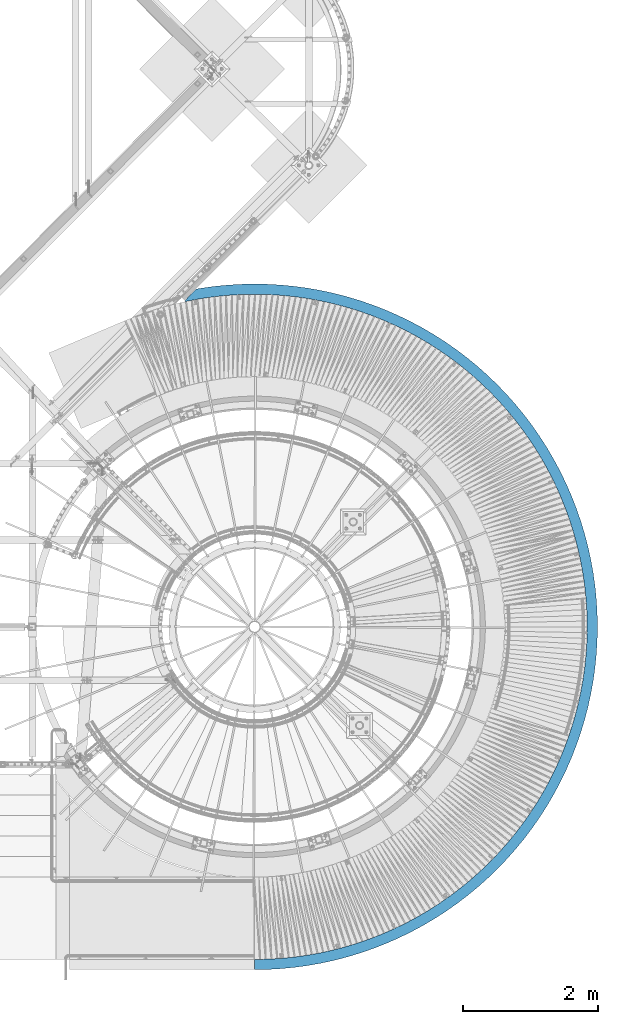
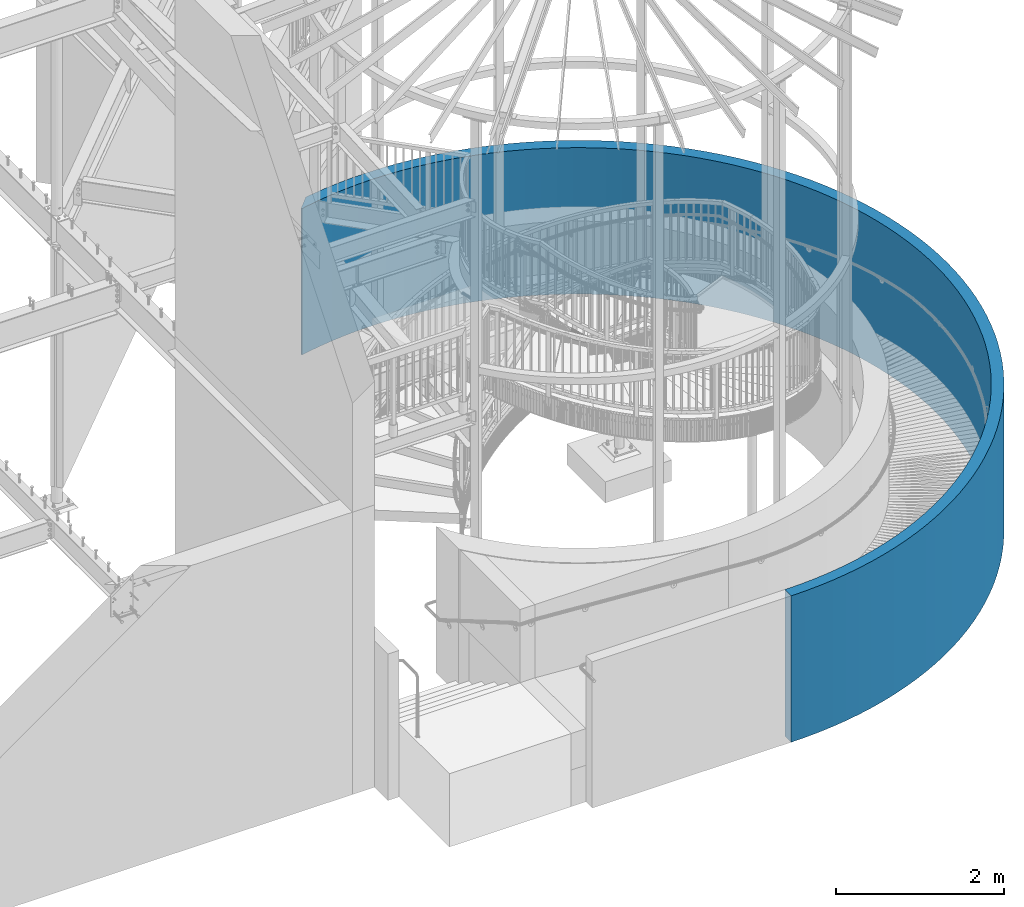
# One storey, part 362 of 975: 1 beam.
"""IFC2X3 building model written with IfcOpenShell, lengths in millimetres."""

from ifc_helpers import new_model, si_unit, frame, origin_with_axes, place, context, subcontext, project, spatial, faceted_brep, material, type_object, element, save


model = new_model("IFC2X3")

# Units and contexts
model_context = context("Model", 3, precision=1e-05, world=origin_with_axes())
body_context = subcontext(model_context, "Body", "Model", "MODEL_VIEW")
ifc_project = project(units=[si_unit("LENGTHUNIT", "METRE", prefix="MILLI"), si_unit("AREAUNIT", "SQUARE_METRE"), si_unit("VOLUMEUNIT", "CUBIC_METRE"), si_unit("MASSUNIT", "GRAM", prefix="KILO"), si_unit("TIMEUNIT", "SECOND"), si_unit("PLANEANGLEUNIT", "RADIAN"), si_unit("SOLIDANGLEUNIT", "STERADIAN"), si_unit("THERMODYNAMICTEMPERATUREUNIT", "DEGREE_CELSIUS"), si_unit("LUMINOUSINTENSITYUNIT", "LUMEN")], contexts=[model_context])

# Site, building, storey
site_placement = place(None, origin_with_axes())
site = spatial("IfcSite", under=ifc_project, at=site_placement, CompositionType="ELEMENT")
building_placement = place(site_placement, origin_with_axes())
building = spatial("IfcBuilding", under=site, at=building_placement, Name="Undefined", CompositionType="ELEMENT")
storey_placement = place(building_placement, origin_with_axes())
storey = spatial("IfcBuildingStorey", under=building, at=storey_placement, Name="Undefined", CompositionType="ELEMENT", Elevation=0.0)

# Beam
ifc_material = material(Name="STEEL/Zero_Density")
beam_type = type_object("IfcBeamType", PredefinedType="NOTDEFINED")
beam_placement = place(storey_placement, frame((34734.5000002246, 3403.60000026434, 2133.6), z_axis=(0.0, -1.0, 0.0), x_axis=(0.0, 0.0, -1.0)))
element("IfcBeam", 1, at=beam_placement, inside=storey, type_object=beam_type, material=ifc_material, Name="WALL", context=body_context, shape_type="Brep", body=[
    faceted_brep([(2133.6, 0.000133240799186751, 5079.99999999993), (0.0, 0.0, 5080.0), (0.0, 0.0, 4927.6), (2133.6, 0.0, 4927.6), (2133.6, -1031.57951941627, -4833.76233125407), (0.0, -1031.57951941627, -4833.76233125407), (0.0, -869.616967607908, -5004.07599048647), (2133.6, -869.616967607959, -5004.07599048646), (2133.6, -1029.59786975904, -4817.938464814), (0.0, -1029.59786975906, -4817.938464814), (0.0, 193.456668134386, 4923.80099897979), (2133.6, 193.456668134386, 4923.80099897979), (0.0, 386.615040108532, 4912.40985370336), (2133.6, 386.615040108532, 4912.40985370336), (0.0, 579.177279713243, 4893.4441284911), (2133.6, 579.177279713243, 4893.4441284911), (0.0, 770.846469932243, 4866.9330671166), (2133.6, 770.846469932243, 4866.9330671166), (0.0, 961.327070766674, 4832.91754771496), (2133.6, 961.327070766674, 4832.91754771496), (0.0, 1150.32537493636, 4791.45001975159), (2133.6, 1150.32537493636, 4791.45001975159), (0.0, 1337.54996075514, 4742.59442314899), (2133.6, 1337.54996075514, 4742.59442314899), (0.0, 1522.71214148199, 4686.426089696), (2133.6, 1522.71214148199, 4686.426089696), (0.0, 1705.52641045506, 4623.03162689163), (2133.6, 1705.52641045506, 4623.03162689163), (0.0, 1885.71088132222, 4552.50878440262), (2133.6, 1885.71088132222, 4552.50878440262), (0.0, 2062.98772268943, 4474.96630334047), (2133.6, 2062.98772268943, 4474.96630334047), (0.0, 2237.08358651659, 4390.5237485906), (2133.6, 2237.08358651659, 4390.5237485906), (0.0, 2407.7300296004, 4299.31132445191), (2133.6, 2407.7300296004, 4299.31132445191), (0.0, 2574.66392749431, 4201.46967387123), (2133.6, 2574.66392749431, 4201.46967387123), (0.0, 2737.6278802274, 4097.14966158202), (2133.6, 2737.6278802274, 4097.14966158202), (0.0, 2896.37060919639, 3986.51214148199), (2133.6, 2896.37060919639, 3986.51214148199), (0.0, 3050.64734461914, 3869.72770860796), (2133.6, 3050.64734461914, 3869.72770860796), (0.0, 3200.22020295182, 3746.97643609071), (2133.6, 3200.22020295182, 3746.97643609071), (0.0, 3344.85855368812, 3618.44759749528), (2133.6, 3344.85855368812, 3618.44759749528), (0.0, 3484.33937497484, 3484.33937497483), (2133.6, 3484.33937497484, 3484.33937497483), (0.0, 3618.44759749529, 3344.85855368812), (2133.6, 3618.44759749529, 3344.85855368812), (0.0, 3746.97643609071, 3200.22020295181), (2133.6, 3746.97643609071, 3200.22020295181), (0.0, 3869.72770860796, 3050.64734461914), (2133.6, 3869.72770860796, 3050.64734461914), (0.0, 3986.512141482, 2896.37060919639), (2133.6, 3986.512141482, 2896.37060919639), (0.0, 4097.14966158202, 2737.62788022739), (2133.6, 4097.14966158202, 2737.62788022739), (0.0, 4201.46967387122, 2574.66392749431), (2133.6, 4201.46967387122, 2574.66392749431), (0.0, 4299.31132445191, 2407.7300296004), (2133.6, 4299.31132445191, 2407.7300296004), (0.0, 4390.5237485906, 2237.08358651659), (2133.6, 4390.5237485906, 2237.08358651659), (0.0, 4474.96630334047, 2062.98772268943), (2133.6, 4474.96630334047, 2062.98772268943), (0.0, 4552.50878440262, 1885.71088132222), (2133.6, 4552.50878440262, 1885.71088132222), (0.0, 4623.03162689164, 1705.52641045505), (2133.6, 4623.03162689164, 1705.52641045505), (0.0, 4686.426089696, 1522.71214148199), (2133.6, 4686.426089696, 1522.71214148199), (0.0, 4742.59442314899, 1337.54996075514), (2133.6, 4742.59442314899, 1337.54996075514), (0.0, 4791.4500197516, 1150.32537493636), (2133.6, 4791.4500197516, 1150.32537493636), (0.0, 4832.91754771496, 961.327070766674), (2133.6, 4832.91754771496, 961.327070766674), (0.0, 4866.9330671166, 770.846469932241), (2133.6, 4866.9330671166, 770.846469932241), (0.0, 4893.44412849109, 579.177279713239), (2133.6, 4893.44412849109, 579.177279713239), (0.0, 4912.40985370336, 386.615040108528), (2133.6, 4912.40985370336, 386.615040108528), (0.0, 4923.80099897979, 193.456668134387), (2133.6, 4923.80099897979, 193.456668134387), (0.0, 4927.6, -4.54747350886464e-13), (2133.6, 4927.6, -4.54747350886464e-13), (0.0, 4923.80099897979, -193.456668134388), (2133.6, 4923.80099897979, -193.456668134388), (0.0, 4912.40985370336, -386.615040108529), (2133.6, 4912.40985370336, -386.615040108529), (0.0, 4893.44412849109, -579.17727971324), (2133.6, 4893.44412849109, -579.17727971324), (0.0, 4866.9330671166, -770.846469932243), (2133.6, 4866.9330671166, -770.846469932243), (0.0, 4832.91754771496, -961.327070766676), (2133.6, 4832.91754771496, -961.327070766676), (0.0, 4791.4500197516, -1150.32537493636), (2133.6, 4791.4500197516, -1150.32537493636), (0.0, 4742.59442314899, -1337.54996075514), (2133.6, 4742.59442314899, -1337.54996075514), (0.0, 4686.426089696, -1522.71214148199), (2133.6, 4686.426089696, -1522.71214148199), (0.0, 4623.03162689164, -1705.52641045506), (2133.6, 4623.03162689164, -1705.52641045506), (0.0, 4552.50878440262, -1885.71088132222), (2133.6, 4552.50878440262, -1885.71088132222), (0.0, 4474.96630334047, -2062.98772268943), (2133.6, 4474.96630334047, -2062.98772268943), (0.0, 4390.5237485906, -2237.08358651659), (2133.6, 4390.5237485906, -2237.08358651659), (0.0, 4299.31132445191, -2407.7300296004), (2133.6, 4299.31132445191, -2407.7300296004), (0.0, 4201.46967387122, -2574.66392749431), (2133.6, 4201.46967387122, -2574.66392749431), (0.0, 4097.14966158202, -2737.62788022739), (2133.6, 4097.14966158202, -2737.62788022739), (0.0, 3986.51214148199, -2896.37060919639), (2133.6, 3986.51214148199, -2896.37060919639), (0.0, 3869.72770860796, -3050.64734461914), (2133.6, 3869.72770860796, -3050.64734461914), (0.0, 3746.97643609071, -3200.22020295181), (2133.6, 3746.97643609071, -3200.22020295181), (0.0, 3618.44759749529, -3344.85855368812), (2133.6, 3618.44759749529, -3344.85855368812), (0.0, 3484.33937497483, -3484.33937497483), (2133.6, 3484.33937497483, -3484.33937497483), (0.0, 3344.85855368812, -3618.44759749528), (2133.6, 3344.85855368812, -3618.44759749528), (0.0, 3200.22020295182, -3746.97643609071), (2133.6, 3200.22020295182, -3746.97643609071), (0.0, 3050.64734461914, -3869.72770860796), (2133.6, 3050.64734461914, -3869.72770860796), (0.0, 2896.37060919639, -3986.51214148199), (2133.6, 2896.37060919639, -3986.51214148199), (0.0, 2737.62788022739, -4097.14966158202), (2133.6, 2737.62788022739, -4097.14966158202), (0.0, 2574.66392749431, -4201.46967387122), (2133.6, 2574.66392749431, -4201.46967387122), (0.0, 2407.7300296004, -4299.31132445192), (2133.6, 2407.7300296004, -4299.31132445192), (0.0, 2237.08358651659, -4390.5237485906), (2133.6, 2237.08358651659, -4390.5237485906), (0.0, 2062.98772268943, -4474.96630334047), (2133.6, 2062.98772268943, -4474.96630334047), (0.0, 1885.71088132221, -4552.50878440262), (2133.6, 1885.71088132221, -4552.50878440262), (0.0, 1705.52641045505, -4623.03162689163), (2133.6, 1705.52641045505, -4623.03162689163), (0.0, 1522.71214148199, -4686.426089696), (2133.6, 1522.71214148199, -4686.426089696), (0.0, 1337.54996075514, -4742.59442314899), (2133.6, 1337.54996075514, -4742.59442314899), (0.0, 1150.32537493636, -4791.45001975159), (2133.6, 1150.32537493636, -4791.45001975159), (0.0, 961.327070766674, -4832.91754771496), (2133.6, 961.327070766674, -4832.91754771496), (0.0, 770.846469932243, -4866.9330671166), (2133.6, 770.846469932243, -4866.9330671166), (0.0, 579.177279713243, -4893.4441284911), (2133.6, 579.177279713243, -4893.4441284911), (0.0, 386.615040108525, -4912.40985370336), (2133.6, 386.615040108525, -4912.40985370336), (0.0, 193.456668134386, -4923.80099897979), (2133.6, 193.456668134386, -4923.80099897979), (0.0, 0.0, -4927.6), (2133.6, 0.0, -4927.6), (0.0, -193.456668134386, -4923.80099897979), (2133.6, -193.456668134386, -4923.80099897979), (0.0, -386.615040108532, -4912.40985370336), (2133.6, -386.615040108532, -4912.40985370336), (0.0, -579.177279713243, -4893.4441284911), (2133.6, -579.177279713243, -4893.4441284911), (0.0, -770.846469932243, -4866.9330671166), (2133.6, -770.846469932243, -4866.9330671166), (0.0, -961.327070766674, -4832.91754771496), (2133.6, -961.327070766674, -4832.91754771496), (0.0, -794.687082404373, -5017.4567702233), (2133.6, -794.687082404373, -5017.4567702233), (0.0, -597.089979085817, -5044.78776133102), (2133.6, -597.089979085817, -5044.78776133102), (0.0, -398.572206297453, -5064.34005536429), (2133.6, -398.572206297453, -5064.34005536429), (0.0, -199.439864056068, -5076.08350410287), (2133.6, -199.439864056068, -5076.08350410287), (0.0, 0.0, -5080.0), (2133.6, 0.0, -5080.0), (0.0, 199.439864056068, -5076.08350410287), (2133.6, 199.439864056068, -5076.08350410287), (0.0, 398.572206297453, -5064.34005536429), (2133.6, 398.572206297453, -5064.34005536429), (0.0, 597.089979085817, -5044.78776133102), (2133.6, 597.089979085817, -5044.78776133102), (0.0, 794.687082404373, -5017.4567702233), (2133.6, 794.687082404373, -5017.4567702233), (0.0, 991.058835841934, -4982.38922444841), (2133.6, 991.058835841934, -4982.38922444841), (0.0, 1185.902448388, -4939.6391956202), (2133.6, 1185.902448388, -4939.6391956202), (0.0, 1378.91748531457, -4889.27260118453), (2133.6, 1378.91748531457, -4889.27260118453), (0.0, 1569.80633142473, -4831.36710277938), (2133.6, 1569.80633142473, -4831.36710277938), (0.0, 1758.27464995367, -4766.01198648622), (2133.6, 1758.27464995367, -4766.01198648622), (0.0, 1944.03183641466, -4693.30802515734), (2133.6, 1944.03183641466, -4693.30802515734), (0.0, 2126.79146669013, -4613.36732303141), (2133.6, 2126.79146669013, -4613.36732303141), (0.0, 2306.2717386769, -4526.31314287691), (2133.6, 2306.2717386769, -4526.31314287691), (0.0, 2482.19590680453, -4432.27971592981), (2133.6, 2482.19590680453, -4432.27971592981), (0.0, 2654.29270875702, -4331.41203491879), (2133.6, 2654.29270875702, -4331.41203491879), (0.0, 2822.29678373958, -4223.86563049693), (2133.6, 2822.29678373958, -4223.86563049693), (0.0, 2985.94908164576, -4109.80633142473), (2133.6, 2985.94908164576, -4109.80633142473), (0.0, 3144.99726249396, -3989.41000887418), (2133.6, 3144.99726249396, -3989.41000887418), (0.0, 3299.19608551734, -3862.86230524815), (2133.6, 3299.19608551734, -3862.86230524815), (0.0, 3448.30778730734, -3730.35834793328), (2133.6, 3448.30778730734, -3730.35834793328), (0.0, 3592.10244842766, -3592.10244842766), (2133.6, 3592.10244842766, -3592.10244842766), (0.0, 3730.35834793328, -3448.30778730734), (2133.6, 3730.35834793328, -3448.30778730734), (0.0, 3862.86230524816, -3299.19608551733), (2133.6, 3862.86230524816, -3299.19608551733), (0.0, 3989.41000887418, -3144.99726249396), (2133.6, 3989.41000887418, -3144.99726249396), (0.0, 4109.80633142473, -2985.94908164576), (2133.6, 4109.80633142473, -2985.94908164576), (0.0, 4223.86563049693, -2822.29678373958), (2133.6, 4223.86563049693, -2822.29678373958), (0.0, 4331.41203491879, -2654.29270875702), (2133.6, 4331.41203491879, -2654.29270875702), (0.0, 4432.27971592981, -2482.19590680453), (2133.6, 4432.27971592981, -2482.19590680453), (0.0, 4526.31314287691, -2306.2717386769), (2133.6, 4526.31314287691, -2306.2717386769), (0.0, 4613.36732303142, -2126.79146669013), (2133.6, 4613.36732303142, -2126.79146669013), (0.0, 4693.30802515733, -1944.03183641466), (2133.6, 4693.30802515733, -1944.03183641466), (0.0, 4766.01198648622, -1758.27464995366), (2133.6, 4766.01198648622, -1758.27464995366), (0.0, 4831.36710277938, -1569.80633142473), (2133.6, 4831.36710277938, -1569.80633142473), (0.0, 4889.27260118453, -1378.91748531458), (2133.6, 4889.27260118453, -1378.91748531458), (0.0, 4939.6391956202, -1185.902448388), (2133.6, 4939.6391956202, -1185.902448388), (0.0, 4982.38922444841, -991.058835841932), (2133.6, 4982.38922444841, -991.058835841932), (0.0, 5017.4567702233, -794.687082404372), (2133.6, 5017.4567702233, -794.687082404372), (0.0, 5044.78776133103, -597.089979085813), (2133.6, 5044.78776133103, -597.089979085813), (0.0, 5064.34005536429, -398.572206297451), (2133.6, 5064.34005536429, -398.572206297451), (0.0, 5076.08350410287, -199.439864056069), (2133.6, 5076.08350410287, -199.439864056069), (0.0, 5080.0, 4.54747350886464e-13), (2133.6, 5080.0, 4.54747350886464e-13), (0.0, 5076.08350410287, 199.43986405607), (2133.6, 5076.08350410287, 199.43986405607), (0.0, 5064.34005536429, 398.572206297453), (2133.6, 5064.34005536429, 398.572206297453), (0.0, 5044.78776133103, 597.089979085815), (2133.6, 5044.78776133103, 597.089979085815), (0.0, 5017.4567702233, 794.687082404374), (2133.6, 5017.4567702233, 794.687082404374), (0.0, 4982.38922444841, 991.058835841933), (2133.6, 4982.38922444841, 991.058835841933), (0.0, 4939.6391956202, 1185.902448388), (2133.6, 4939.6391956202, 1185.902448388), (0.0, 4889.27260118453, 1378.91748531458), (2133.6, 4889.27260118453, 1378.91748531458), (0.0, 4831.36710277938, 1569.80633142473), (2133.6, 4831.36710277938, 1569.80633142473), (0.0, 4766.01198648622, 1758.27464995367), (2133.6, 4766.01198648622, 1758.27464995367), (0.0, 4693.30802515733, 1944.03183641466), (2133.6, 4693.30802515733, 1944.03183641466), (0.0, 4613.36732303142, 2126.79146669013), (2133.6, 4613.36732303142, 2126.79146669013), (0.0, 4526.3131428769, 2306.2717386769), (2133.6, 4526.3131428769, 2306.2717386769), (0.0, 4432.27971592981, 2482.19590680453), (2133.6, 4432.27971592981, 2482.19590680453), (0.0, 4331.41203491879, 2654.29270875702), (2133.6, 4331.41203491879, 2654.29270875702), (0.0, 4223.86563049693, 2822.29678373958), (2133.6, 4223.86563049693, 2822.29678373958), (0.0, 4109.80633142473, 2985.94908164576), (2133.6, 4109.80633142473, 2985.94908164576), (0.0, 3989.41000887418, 3144.99726249396), (2133.6, 3989.41000887418, 3144.99726249396), (0.0, 3862.86230524816, 3299.19608551733), (2133.6, 3862.86230524816, 3299.19608551733), (0.0, 3730.35834793328, 3448.30778730734), (2133.6, 3730.35834793328, 3448.30778730734), (0.0, 3592.10244842766, 3592.10244842766), (2133.6, 3592.10244842766, 3592.10244842766), (0.0, 3448.30778730734, 3730.35834793328), (2133.6, 3448.30778730734, 3730.35834793328), (0.0, 3299.19608551733, 3862.86230524816), (2133.6, 3299.19608551733, 3862.86230524816), (0.0, 3144.99726249395, 3989.41000887418), (2133.6, 3144.99726249395, 3989.41000887418), (0.0, 2985.94908164576, 4109.80633142473), (2133.6, 2985.94908164576, 4109.80633142473), (0.0, 2822.29678373958, 4223.86563049693), (2133.6, 2822.29678373958, 4223.86563049693), (0.0, 2654.29270875702, 4331.41203491879), (2133.6, 2654.29270875702, 4331.41203491879), (0.0, 2482.19590680453, 4432.27971592981), (2133.6, 2482.19590680453, 4432.27971592981), (0.0, 2306.2717386769, 4526.31314287691), (2133.6, 2306.2717386769, 4526.31314287691), (0.0, 2126.79146669013, 4613.36732303141), (2133.6, 2126.79146669013, 4613.36732303141), (0.0, 1944.03183641466, 4693.30802515734), (2133.6, 1944.03183641466, 4693.30802515734), (0.0, 1758.27464995367, 4766.01198648622), (2133.6, 1758.27464995367, 4766.01198648622), (0.0, 1569.80633142473, 4831.36710277938), (2133.6, 1569.80633142473, 4831.36710277938), (0.0, 1378.91748531457, 4889.27260118453), (2133.6, 1378.91748531457, 4889.27260118453), (0.0, 1185.902448388, 4939.6391956202), (2133.6, 1185.902448388, 4939.6391956202), (0.0, 991.058835841934, 4982.38922444841), (2133.6, 991.058835841934, 4982.38922444841), (0.0, 794.687082404373, 5017.4567702233), (2133.6, 794.687082404373, 5017.4567702233), (0.0, 597.089979085817, 5044.78776133103), (2133.6, 597.089979085817, 5044.78776133103), (0.0, 398.572206297453, 5064.34005536429), (2133.6, 398.572206297453, 5064.34005536429), (2133.6, 199.439864056068, 5076.08350410287), (0.0, 199.439864056068, 5076.08350410287)], [[[0, 1, 2, 3]], [[4, 5, 6, 7]], [[8, 9, 5, 4]], [[10, 11, 3, 2]], [[10, 12, 13, 11]], [[12, 14, 15, 13]], [[14, 16, 17, 15]], [[16, 18, 19, 17]], [[18, 20, 21, 19]], [[20, 22, 23, 21]], [[22, 24, 25, 23]], [[24, 26, 27, 25]], [[26, 28, 29, 27]], [[28, 30, 31, 29]], [[30, 32, 33, 31]], [[32, 34, 35, 33]], [[34, 36, 37, 35]], [[36, 38, 39, 37]], [[38, 40, 41, 39]], [[40, 42, 43, 41]], [[42, 44, 45, 43]], [[44, 46, 47, 45]], [[46, 48, 49, 47]], [[48, 50, 51, 49]], [[50, 52, 53, 51]], [[52, 54, 55, 53]], [[54, 56, 57, 55]], [[56, 58, 59, 57]], [[58, 60, 61, 59]], [[60, 62, 63, 61]], [[62, 64, 65, 63]], [[64, 66, 67, 65]], [[66, 68, 69, 67]], [[68, 70, 71, 69]], [[70, 72, 73, 71]], [[72, 74, 75, 73]], [[74, 76, 77, 75]], [[76, 78, 79, 77]], [[78, 80, 81, 79]], [[80, 82, 83, 81]], [[82, 84, 85, 83]], [[84, 86, 87, 85]], [[86, 88, 89, 87]], [[88, 90, 91, 89]], [[90, 92, 93, 91]], [[92, 94, 95, 93]], [[94, 96, 97, 95]], [[96, 98, 99, 97]], [[98, 100, 101, 99]], [[100, 102, 103, 101]], [[102, 104, 105, 103]], [[104, 106, 107, 105]], [[106, 108, 109, 107]], [[108, 110, 111, 109]], [[110, 112, 113, 111]], [[112, 114, 115, 113]], [[114, 116, 117, 115]], [[116, 118, 119, 117]], [[118, 120, 121, 119]], [[120, 122, 123, 121]], [[122, 124, 125, 123]], [[124, 126, 127, 125]], [[126, 128, 129, 127]], [[128, 130, 131, 129]], [[130, 132, 133, 131]], [[132, 134, 135, 133]], [[134, 136, 137, 135]], [[136, 138, 139, 137]], [[138, 140, 141, 139]], [[140, 142, 143, 141]], [[142, 144, 145, 143]], [[144, 146, 147, 145]], [[146, 148, 149, 147]], [[148, 150, 151, 149]], [[150, 152, 153, 151]], [[152, 154, 155, 153]], [[154, 156, 157, 155]], [[156, 158, 159, 157]], [[158, 160, 161, 159]], [[160, 162, 163, 161]], [[162, 164, 165, 163]], [[164, 166, 167, 165]], [[166, 168, 169, 167]], [[168, 170, 171, 169]], [[170, 172, 173, 171]], [[172, 174, 175, 173]], [[174, 176, 177, 175]], [[176, 178, 179, 177]], [[180, 181, 7, 6]], [[180, 182, 183, 181]], [[182, 184, 185, 183]], [[184, 186, 187, 185]], [[186, 188, 189, 187]], [[188, 190, 191, 189]], [[190, 192, 193, 191]], [[192, 194, 195, 193]], [[194, 196, 197, 195]], [[196, 198, 199, 197]], [[198, 200, 201, 199]], [[200, 202, 203, 201]], [[202, 204, 205, 203]], [[204, 206, 207, 205]], [[206, 208, 209, 207]], [[208, 210, 211, 209]], [[210, 212, 213, 211]], [[212, 214, 215, 213]], [[214, 216, 217, 215]], [[216, 218, 219, 217]], [[218, 220, 221, 219]], [[220, 222, 223, 221]], [[222, 224, 225, 223]], [[224, 226, 227, 225]], [[226, 228, 229, 227]], [[228, 230, 231, 229]], [[230, 232, 233, 231]], [[232, 234, 235, 233]], [[234, 236, 237, 235]], [[236, 238, 239, 237]], [[238, 240, 241, 239]], [[240, 242, 243, 241]], [[242, 244, 245, 243]], [[244, 246, 247, 245]], [[246, 248, 249, 247]], [[248, 250, 251, 249]], [[250, 252, 253, 251]], [[252, 254, 255, 253]], [[254, 256, 257, 255]], [[256, 258, 259, 257]], [[258, 260, 261, 259]], [[260, 262, 263, 261]], [[262, 264, 265, 263]], [[264, 266, 267, 265]], [[266, 268, 269, 267]], [[268, 270, 271, 269]], [[270, 272, 273, 271]], [[272, 274, 275, 273]], [[274, 276, 277, 275]], [[276, 278, 279, 277]], [[278, 280, 281, 279]], [[280, 282, 283, 281]], [[282, 284, 285, 283]], [[284, 286, 287, 285]], [[286, 288, 289, 287]], [[288, 290, 291, 289]], [[290, 292, 293, 291]], [[292, 294, 295, 293]], [[294, 296, 297, 295]], [[296, 298, 299, 297]], [[298, 300, 301, 299]], [[300, 302, 303, 301]], [[302, 304, 305, 303]], [[304, 306, 307, 305]], [[306, 308, 309, 307]], [[308, 310, 311, 309]], [[310, 312, 313, 311]], [[312, 314, 315, 313]], [[314, 316, 317, 315]], [[316, 318, 319, 317]], [[318, 320, 321, 319]], [[320, 322, 323, 321]], [[322, 324, 325, 323]], [[324, 326, 327, 325]], [[326, 328, 329, 327]], [[328, 330, 331, 329]], [[330, 332, 333, 331]], [[332, 334, 335, 333]], [[334, 336, 337, 335]], [[336, 338, 339, 337]], [[338, 340, 341, 339]], [[340, 342, 343, 341]], [[342, 344, 345, 343]], [[11, 13, 15, 17, 19, 21, 23, 25, 27, 29, 31, 33, 35, 37, 39, 41, 43, 45, 47, 49, 51, 53, 55, 57, 59, 61, 63, 65, 67, 69, 71, 73, 75, 77, 79, 81, 83, 85, 87, 89, 91, 93, 95, 97, 99, 101, 103, 105, 107, 109, 111, 113, 115, 117, 119, 121, 123, 125, 127, 129, 131, 133, 135, 137, 139, 141, 143, 145, 147, 149, 151, 153, 155, 157, 159, 161, 163, 165, 167, 169, 171, 173, 175, 177, 179, 8, 4, 7, 181, 183, 185, 187, 189, 191, 193, 195, 197, 199, 201, 203, 205, 207, 209, 211, 213, 215, 217, 219, 221, 223, 225, 227, 229, 231, 233, 235, 237, 239, 241, 243, 245, 247, 249, 251, 253, 255, 257, 259, 261, 263, 265, 267, 269, 271, 273, 275, 277, 279, 281, 283, 285, 287, 289, 291, 293, 295, 297, 299, 301, 303, 305, 307, 309, 311, 313, 315, 317, 319, 321, 323, 325, 327, 329, 331, 333, 335, 337, 339, 341, 343, 345, 346, 0, 3]], [[344, 347, 346, 345]], [[346, 347, 1, 0]], [[347, 344, 342, 340, 338, 336, 334, 332, 330, 328, 326, 324, 322, 320, 318, 316, 314, 312, 310, 308, 306, 304, 302, 300, 298, 296, 294, 292, 290, 288, 286, 284, 282, 280, 278, 276, 274, 272, 270, 268, 266, 264, 262, 260, 258, 256, 254, 252, 250, 248, 246, 244, 242, 240, 238, 236, 234, 232, 230, 228, 226, 224, 222, 220, 218, 216, 214, 212, 210, 208, 206, 204, 202, 200, 198, 196, 194, 192, 190, 188, 186, 184, 182, 180, 6, 5, 9, 178, 176, 174, 172, 170, 168, 166, 164, 162, 160, 158, 156, 154, 152, 150, 148, 146, 144, 142, 140, 138, 136, 134, 132, 130, 128, 126, 124, 122, 120, 118, 116, 114, 112, 110, 108, 106, 104, 102, 100, 98, 96, 94, 92, 90, 88, 86, 84, 82, 80, 78, 76, 74, 72, 70, 68, 66, 64, 62, 60, 58, 56, 54, 52, 50, 48, 46, 44, 42, 40, 38, 36, 34, 32, 30, 28, 26, 24, 22, 20, 18, 16, 14, 12, 10, 2, 1]], [[179, 178, 9, 8]]]),
])

save(model, "model.ifc")
